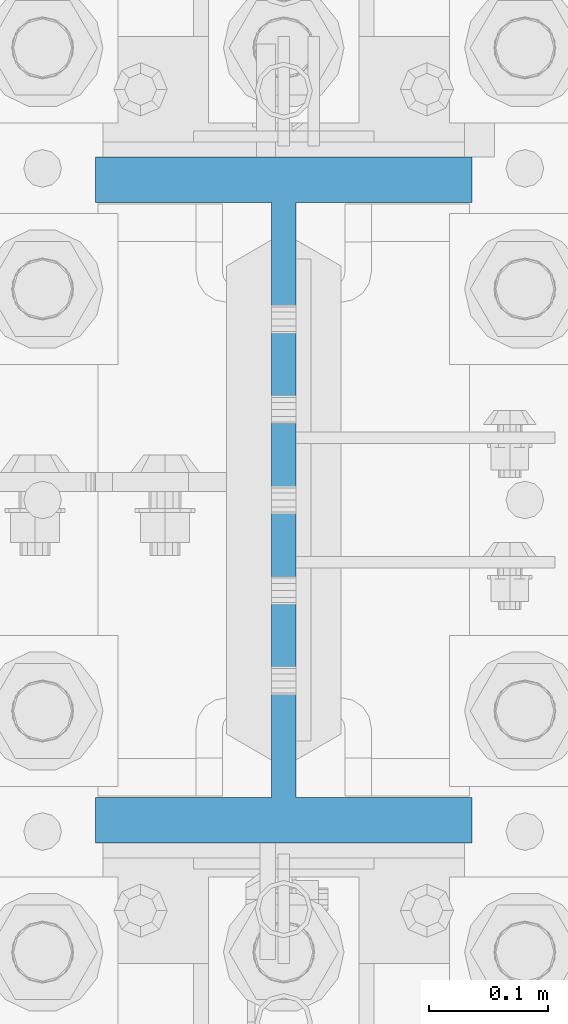
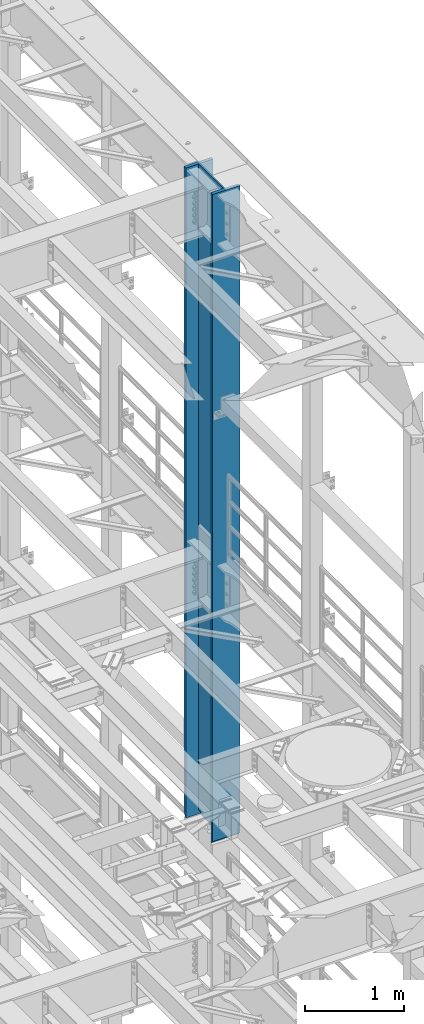
# One storey, part 757 of 1876: 1 column, 1 element without a shape of its own.
"""IFC2X3 building model written with IfcOpenShell, lengths in millimetres."""

from ifc_helpers import new_model, si_unit, frame, origin_with_axes, place, context, subcontext, project, spatial, faceted_brep, material, type_object, element, aggregate, save


model = new_model("IFC2X3")

# Units and contexts
model_context = context("Model", 3, precision=1e-05, world=origin_with_axes())
body_context = subcontext(model_context, "Body", "Model", "MODEL_VIEW")
ifc_project = project(units=[si_unit("LENGTHUNIT", "METRE", prefix="MILLI"), si_unit("AREAUNIT", "SQUARE_METRE"), si_unit("VOLUMEUNIT", "CUBIC_METRE"), si_unit("MASSUNIT", "GRAM", prefix="KILO"), si_unit("TIMEUNIT", "SECOND"), si_unit("PLANEANGLEUNIT", "RADIAN"), si_unit("SOLIDANGLEUNIT", "STERADIAN"), si_unit("THERMODYNAMICTEMPERATUREUNIT", "DEGREE_CELSIUS"), si_unit("LUMINOUSINTENSITYUNIT", "LUMEN")], contexts=[model_context])

# Site, building, storey
site_placement = place(None, origin_with_axes())
site = spatial("IfcSite", under=ifc_project, at=site_placement, CompositionType="ELEMENT")
building_placement = place(site_placement, origin_with_axes())
building = spatial("IfcBuilding", under=site, at=building_placement, Name="Undefined", CompositionType="ELEMENT")
storey_placement = place(building_placement, origin_with_axes())
storey = spatial("IfcBuildingStorey", under=building, at=storey_placement, Name="Undefined", CompositionType="ELEMENT", Elevation=0.0)

# Assembly, column
assembly_placement = place(storey_placement, origin_with_axes())
assembly = element("IfcElementAssembly", 1, at=assembly_placement, inside=storey, Name="COLUMN", AssemblyPlace="NOTDEFINED", PredefinedType="RIGID_FRAME")
ifc_material = material(Name="STEEL/A992")
column_type = type_object("IfcColumnType", Name="W21X182", PredefinedType="NOTDEFINED")
column_placement = place(assembly_placement, frame((7620.0, 7620.0, 14528.8), z_axis=(0.0, 1.0, 0.0), x_axis=(0.0, 0.0, 1.0)))
column = element("IfcColumn", 2, at=column_placement, type_object=column_type, material=ifc_material, Name="COLUMN", ObjectType="W21X182", context=body_context, shape_type="Brep", body=[
    faceted_brep([(23.8124996185343, -10.3187499999995, 203.498507902429), (6.35000000000036, 7.14374961853082, 200.025000762939), (6.35000000000036, 7.14374961853082, -200.025000762939), (23.8124996185343, -10.3187500000004, -203.49850776611), (25.7903188351174, -10.3187500000004, -203.891920453291), (25.7903188351174, 10.3187500000004, -203.891920453291), (42.2710247077321, 10.3187500000004, -214.903976055203), (42.2710247077321, -10.3187500000004, -214.903976055203), (53.283080309644, 10.3187500000004, -231.384681927818), (53.283080309644, -10.3187500000004, -231.384681927818), (8026.4, -158.75, 288.925), (8026.4, 158.75, 288.925), (41.2749999999833, 158.75, 288.925), (41.2749999999833, -158.75, 288.925), (6.35000000000036, -158.75, 250.825), (57.1499992370573, -158.75, 250.825), (8026.4, -158.75, 250.825), (6.35000000000036, -158.75, 254.00000000002), (6.35000000000036, -10.3187500000004, 250.825), (6.35000000000036, 158.75, 254.00000000002), (6.35000000000036, 158.75, 250.825), (6.35000000000036, 10.3187500000004, 250.825), (6.35000000000036, 7.14374961853082, 250.825), (8026.4, 158.75, 250.825), (57.1499992370573, 158.75, 250.825), (57.1499992370573, 10.3187500000004, 250.825), (8026.4, 10.3187500000004, 250.825), (53.2830795467053, -10.3187500000004, 231.384681927818), (53.2830795467053, 10.3187500000004, 231.384681927818), (42.2710239447933, 10.3187500000004, 214.903976055203), (42.2710239447933, -10.3187500000004, 214.903976055203), (57.1499992370573, -10.3187500000004, 250.825), (23.8124996185343, -10.3187500000004, 250.825), (8026.4, -10.3187500000004, 250.825), (57.149999999996, 158.75, -250.825), (6.35000000000036, 158.75, -250.825), (6.35000000000036, 10.3187500000004, -250.825), (57.1499999999978, 10.3187500000004, -250.825), (8026.4, 10.3187500000004, -250.825), (8026.4, 158.75, -250.825), (8026.4, 158.75, -288.925), (8026.4, -158.75, -288.925), (41.2749999999833, -158.75, -288.925), (41.2749999999833, 158.75, -288.925), (8026.4, -158.75, -250.825), (57.149999999996, -158.75, -250.825), (6.35000000000036, -158.75, -250.825), (6.35000000000036, -158.75, -254.000000000019), (6.35000000000036, 158.75, -254.000000000019), (8026.4, -10.3187500000004, -250.825), (57.149999999996, -10.3187500000004, -250.825), (23.8124996185343, -10.3187500000004, -250.825), (6.35000000000036, -10.3187500000004, -250.825), (6.35000000000036, 7.14374961853082, -250.825), (6.35000000000036, 10.3187500000004, -200.025000762939), (6.35000000000036, 10.3187500000004, 200.025000762939), (25.7903180721787, 10.3187500000004, 203.891920453291), (25.7903180721787, -10.3187500000004, 203.891920453291)], [[[0, 1, 2, 3]], [[4, 5, 6, 7]], [[7, 6, 8, 9]], [[10, 11, 12, 13]], [[14, 15, 16, 10, 13, 17]], [[18, 14, 17, 19, 20, 21, 22]], [[13, 12, 19, 17]], [[11, 23, 24, 20, 19, 12]], [[25, 21, 20, 24, 23, 26]], [[27, 28, 29, 30]], [[31, 25, 28, 27]], [[32, 18, 22, 21, 25, 31]], [[15, 14, 18, 32, 31, 33, 16]], [[34, 35, 36, 37, 38, 39]], [[40, 41, 42, 43]], [[41, 44, 45, 46, 47, 42]], [[42, 47, 48, 43]], [[35, 34, 39, 40, 43, 48]], [[38, 26, 23, 11, 10, 16, 33, 49, 44, 41, 40, 39]], [[50, 51, 52, 46, 45, 44, 49]], [[36, 35, 48, 47, 46, 52, 53]], [[51, 50, 37, 36, 53, 52]], [[9, 8, 37, 50]], [[6, 5, 54, 55, 56, 29, 28, 25, 26, 38, 37, 8]], [[30, 29, 56, 57]], [[4, 7, 9, 50, 49, 33, 31, 27, 30, 57, 0, 3]], [[54, 5, 4, 3, 2]], [[55, 54, 2, 1]], [[57, 56, 55, 1, 0]]]),
])
aggregate(assembly, [column])

save(model, "model.ifc")
